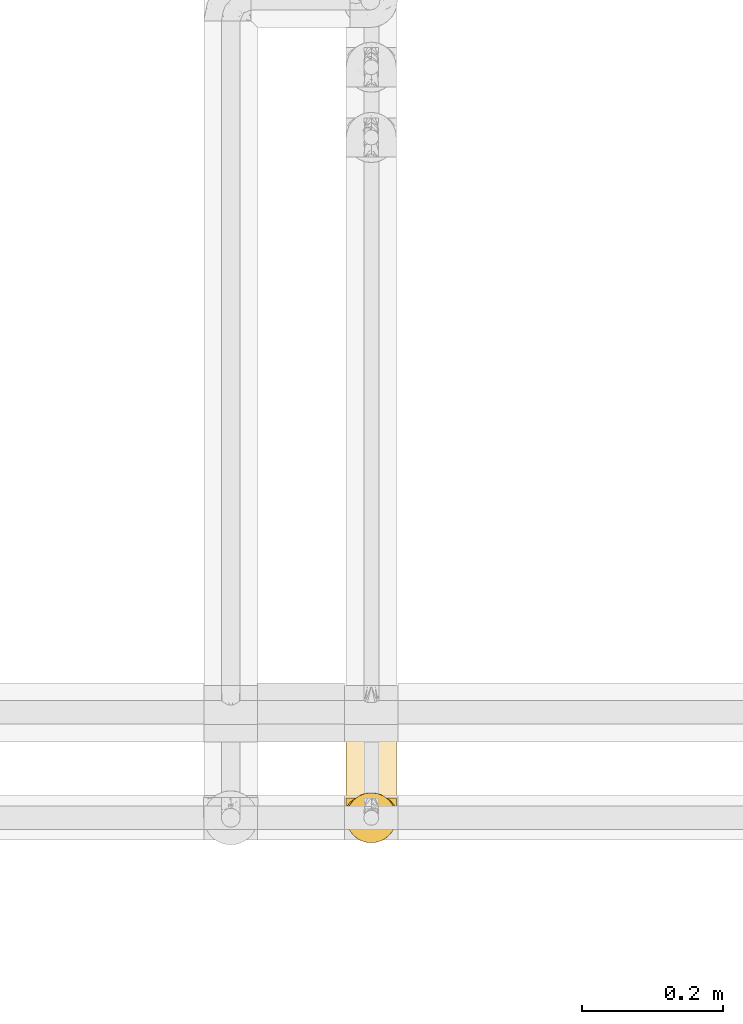
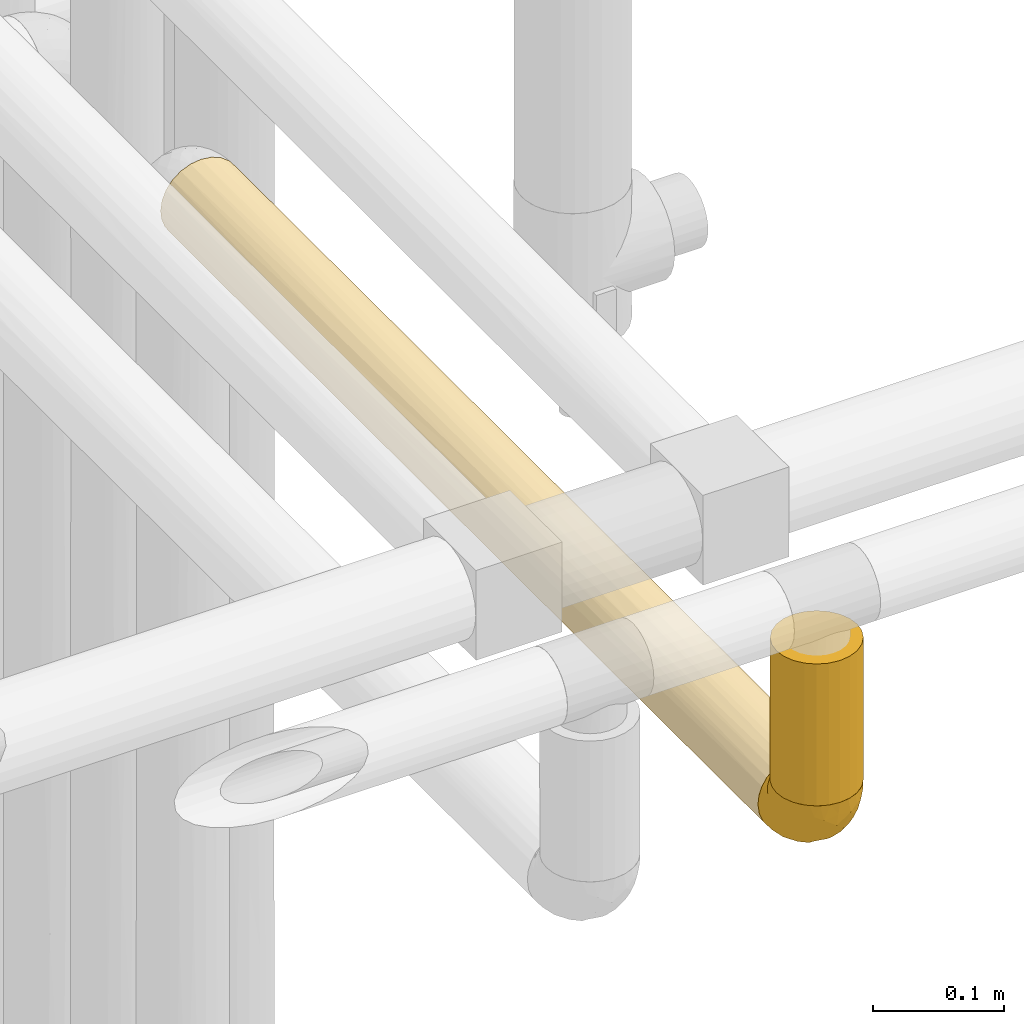
# One storey, part 55 of 827: 3 coverings.
"""IFC2X3 building model written with IfcOpenShell, lengths in millimetres."""

from ifc_helpers import new_model, entity, si_unit, converted_unit, derived_unit, direction, frame, origin, place, context, subcontext, project, spatial, faceted_brep, element, save


model = new_model("IFC2X3")

# Units and contexts
model_context = context("Model", 3, precision=0.01, world=origin(), true_north=direction((6.12303176911189e-17, 1.0)))
body_context = subcontext(model_context, "Body", "Model", "MODEL_VIEW")
ifc_project = project(units=[si_unit("LENGTHUNIT", "METRE", prefix="MILLI"), si_unit("AREAUNIT", "SQUARE_METRE"), si_unit("VOLUMEUNIT", "CUBIC_METRE"), converted_unit("PLANEANGLEUNIT", "DEGREE", entity("IfcRatioMeasure", 0.0174532925199433), si_unit("PLANEANGLEUNIT", "RADIAN"), dimensions=[0, 0, 0, 0, 0, 0, 0]), si_unit("MASSUNIT", "GRAM", prefix="KILO"), derived_unit("MASSDENSITYUNIT", [(si_unit("MASSUNIT", "GRAM", prefix="KILO"), 1), (si_unit("LENGTHUNIT", "METRE"), -3)]), derived_unit("MOMENTOFINERTIAUNIT", [(si_unit("LENGTHUNIT", "METRE"), 4)]), si_unit("TIMEUNIT", "SECOND"), si_unit("FREQUENCYUNIT", "HERTZ"), si_unit("THERMODYNAMICTEMPERATUREUNIT", "DEGREE_CELSIUS"), derived_unit("THERMALTRANSMITTANCEUNIT", [(si_unit("MASSUNIT", "GRAM", prefix="KILO"), 1), (si_unit("THERMODYNAMICTEMPERATUREUNIT", "KELVIN"), -1), (si_unit("TIMEUNIT", "SECOND"), -3)]), derived_unit("VOLUMETRICFLOWRATEUNIT", [(si_unit("LENGTHUNIT", "METRE"), 3), (si_unit("TIMEUNIT", "SECOND"), -1)]), derived_unit("MASSFLOWRATEUNIT", [(si_unit("MASSUNIT", "GRAM", prefix="KILO"), 1), (si_unit("TIMEUNIT", "SECOND"), -1)]), derived_unit("ROTATIONALFREQUENCYUNIT", [(si_unit("TIMEUNIT", "SECOND"), -1)]), si_unit("ELECTRICCURRENTUNIT", "AMPERE"), si_unit("ELECTRICVOLTAGEUNIT", "VOLT"), si_unit("POWERUNIT", "WATT"), si_unit("FORCEUNIT", "NEWTON", prefix="KILO"), si_unit("ILLUMINANCEUNIT", "LUX"), si_unit("LUMINOUSFLUXUNIT", "LUMEN"), si_unit("LUMINOUSINTENSITYUNIT", "CANDELA"), derived_unit("USERDEFINED", [(si_unit("MASSUNIT", "GRAM", prefix="KILO"), -1), (si_unit("LENGTHUNIT", "METRE"), -2), (si_unit("TIMEUNIT", "SECOND"), 3), (si_unit("LUMINOUSFLUXUNIT", "LUMEN"), 1)]), derived_unit("LINEARVELOCITYUNIT", [(si_unit("LENGTHUNIT", "METRE"), 1), (si_unit("TIMEUNIT", "SECOND"), -1)]), si_unit("PRESSUREUNIT", "PASCAL"), derived_unit("USERDEFINED", [(si_unit("LENGTHUNIT", "METRE"), -2), (si_unit("MASSUNIT", "GRAM", prefix="KILO"), 1), (si_unit("TIMEUNIT", "SECOND"), -2)]), derived_unit("LINEARFORCEUNIT", [(si_unit("MASSUNIT", "GRAM", prefix="KILO"), 1), (si_unit("LENGTHUNIT", "METRE"), 1), (si_unit("TIMEUNIT", "SECOND"), -2), (si_unit("LENGTHUNIT", "METRE"), -1)]), derived_unit("PLANARFORCEUNIT", [(si_unit("MASSUNIT", "GRAM", prefix="KILO"), 1), (si_unit("LENGTHUNIT", "METRE"), 1), (si_unit("TIMEUNIT", "SECOND"), -2), (si_unit("LENGTHUNIT", "METRE"), -2)])], contexts=[model_context])

# Site, building, storey
site_placement = place(None, origin())
site = spatial("IfcSite", under=ifc_project, at=site_placement, CompositionType="ELEMENT")
building_placement = place(site_placement, origin())
building = spatial("IfcBuilding", under=site, at=building_placement, CompositionType="ELEMENT")
storey_placement = place(building_placement, frame((0.0, 0.0, 28200.0)))
storey = spatial("IfcBuildingStorey", under=building, at=storey_placement, Name="08", CompositionType="ELEMENT", Elevation=28200.0)

# Coverings
covering_1_placement = place(storey_placement, frame((17891.28, 9619.2, 2614.48)))
element("IfcCovering", 1, at=covering_1_placement, inside=storey, Name=":ADSK_", ObjectType=":ADSK_", PredefinedType="INSULATION", context=body_context, shape_type="Brep", body=[
    faceted_brep([(12.04, 914.0, 62.45), (19.42, 914.0, 68.12), (28.02, 914.0, 71.68), (37.25, 914.0, 72.9), (46.47, 914.0, 71.68), (55.07, 914.0, 68.12), (62.45, 914.0, 62.45), (68.12, 914.0, 55.07), (71.68, 914.0, 46.47), (72.9, 914.0, 37.25), (71.99, 914.0, 29.26), (69.32, 914.0, 21.68), (65.02, 914.0, 14.89), (59.31, 914.0, 9.25), (15.18, 914.0, 9.25), (9.47, 914.0, 14.89), (5.17, 914.0, 21.68), (2.5, 914.0, 29.26), (1.6, 914.0, 37.25), (2.81, 914.0, 46.47), (6.37, 914.0, 55.07), (59.31, 1.6, 65.25), (15.18, 1.6, 65.25), (9.47, 1.6, 59.6), (5.17, 1.6, 52.81), (2.5, 1.6, 45.24), (1.6, 1.6, 37.25), (2.81, 1.6, 28.02), (6.37, 1.6, 19.42), (12.04, 1.6, 12.04), (19.42, 1.6, 6.37), (28.02, 1.6, 2.81), (37.25, 1.6, 1.6), (46.47, 1.6, 2.81), (55.07, 1.6, 6.37), (62.45, 1.6, 12.04), (68.12, 1.6, 19.42), (71.68, 1.6, 28.02), (72.9, 1.6, 37.25), (71.99, 1.6, 45.24), (69.32, 1.6, 52.81), (65.02, 1.6, 59.6), (71.42, 331.97, 27.11), (72.9, 249.32, 37.25), (37.25, 245.49, 1.6), (43.48, 174.27, 2.14), (65.53, 242.64, 15.54), (57.15, 458.31, 7.67), (62.55, 579.77, 12.13), (72.9, 705.52, 37.25), (70.87, 659.33, 25.39), (57.02, 693.42, 7.58), (48.92, 908.32, 3.56), (54.35, 910.72, 5.97), (67.36, 502.79, 18.17), (68.86, 325.58, 20.78), (50.2, 461.14, 4.03), (67.36, 724.75, 18.17), (58.95, 214.6, 8.96), (50.89, 256.26, 4.31), (37.25, 489.39, 1.6), (44.09, 367.44, 2.26), (72.9, 497.04, 37.25), (37.25, 697.87, 1.6), (43.17, 906.85, 2.09), (46.16, 626.74, 2.73), (72.9, 210.08, 37.25), (37.25, 906.35, 1.6), (72.9, 418.56, 37.25), (72.9, 666.28, 37.25), (16.83, 235.14, 8.02), (11.24, 302.68, 12.86), (17.34, 458.31, 7.67), (28.33, 626.74, 2.73), (30.4, 367.44, 2.26), (24.29, 461.14, 4.03), (2.25, 373.18, 30.45), (1.6, 249.32, 37.25), (1.6, 418.56, 37.25), (1.6, 497.04, 37.25), (3.0, 601.28, 27.35), (7.13, 502.79, 18.17), (4.31, 265.31, 23.6), (25.57, 908.32, 3.56), (31.32, 906.85, 2.09), (23.6, 256.26, 4.31), (7.45, 198.07, 17.66), (20.14, 910.72, 5.97), (17.47, 693.42, 7.58), (11.94, 579.77, 12.13), (1.6, 666.28, 37.25), (1.6, 705.52, 37.25), (2.16, 177.62, 30.94), (1.6, 210.08, 37.25), (7.13, 724.75, 18.17), (31.01, 174.27, 2.14), (7.13, 190.84, 56.32), (3.62, 256.26, 49.1), (28.33, 288.86, 71.76), (30.4, 548.16, 72.23), (24.29, 454.46, 70.46), (5.17, 714.59, 52.8), (3.07, 583.63, 47.38), (11.94, 335.82, 62.36), (31.32, 8.75, 72.4), (37.25, 217.73, 72.9), (17.34, 457.29, 66.82), (15.54, 700.99, 65.53), (8.96, 672.96, 58.95), (7.13, 412.8, 56.32), (17.47, 222.17, 66.91), (20.14, 4.87, 68.52), (25.57, 7.28, 70.93), (23.6, 659.34, 70.18), (37.25, 426.21, 72.9), (37.25, 670.1, 72.9), (31.01, 741.33, 72.35), (37.25, 9.25, 72.9), (48.92, 7.28, 70.93), (57.02, 222.17, 66.91), (46.16, 288.86, 71.76), (43.17, 8.75, 72.4), (58.95, 700.99, 65.53), (50.89, 659.34, 70.18), (54.35, 4.87, 68.52), (50.2, 454.46, 70.46), (44.09, 548.16, 72.23), (57.15, 457.29, 66.82), (62.55, 335.82, 62.36), (67.36, 190.84, 56.32), (43.48, 741.33, 72.35), (71.42, 583.63, 47.38), (70.87, 256.26, 49.1), (67.36, 412.8, 56.32), (68.86, 590.01, 53.71), (65.53, 672.96, 58.95)], [[[0, 1, 2, 3, 4, 5, 6, 7, 8, 9, 10, 11, 12, 13, 14, 15, 16, 17, 18, 19, 20]], [[21, 22, 23, 24, 25, 26, 27, 28, 29, 30, 31, 32, 33, 34, 35, 36, 37, 38, 39, 40, 41]], [[42, 43, 37]], [[44, 45, 32]], [[46, 47, 48]], [[10, 49, 50]], [[51, 52, 53]], [[47, 51, 48]], [[54, 50, 42]], [[36, 46, 55]], [[51, 47, 56]], [[50, 54, 57]], [[11, 10, 50]], [[48, 13, 12]], [[57, 12, 11]], [[47, 58, 59]], [[48, 12, 57]], [[60, 61, 44]], [[50, 62, 42]], [[63, 64, 65]], [[37, 43, 66, 38]], [[64, 52, 65]], [[34, 33, 59]], [[53, 13, 51]], [[51, 65, 52]], [[67, 64, 63]], [[65, 56, 61]], [[35, 46, 36]], [[37, 36, 55]], [[58, 35, 34]], [[56, 59, 61]], [[42, 62, 68, 43]], [[46, 35, 58]], [[55, 46, 54]], [[48, 51, 13]], [[46, 48, 54]], [[44, 61, 45]], [[50, 57, 11]], [[48, 57, 54]], [[65, 61, 60]], [[45, 59, 33]], [[59, 58, 34]], [[46, 58, 47]], [[51, 56, 65]], [[47, 59, 56]], [[59, 45, 61]], [[32, 45, 33]], [[65, 60, 63]], [[49, 10, 9]], [[50, 49, 69, 62]], [[54, 42, 55]], [[55, 42, 37]], [[70, 71, 72]], [[73, 74, 75]], [[74, 60, 44]], [[76, 77, 78, 79]], [[80, 81, 82]], [[73, 83, 84]], [[85, 31, 30]], [[81, 86, 82]], [[70, 29, 71]], [[14, 87, 88]], [[83, 73, 88]], [[84, 63, 73]], [[76, 80, 82]], [[14, 89, 15]], [[86, 28, 82]], [[80, 79, 90, 91]], [[92, 26, 93, 77]], [[88, 72, 89]], [[16, 94, 80]], [[81, 89, 71]], [[28, 27, 82]], [[94, 16, 15]], [[75, 88, 73]], [[17, 91, 18]], [[17, 16, 80]], [[95, 85, 74]], [[88, 87, 83]], [[88, 89, 14]], [[86, 81, 71]], [[17, 80, 91]], [[89, 94, 15]], [[71, 89, 72]], [[89, 81, 94]], [[72, 85, 70]], [[29, 28, 86]], [[77, 76, 92]], [[74, 73, 60]], [[31, 95, 32]], [[80, 94, 81]], [[95, 74, 44]], [[74, 85, 75]], [[80, 76, 79]], [[92, 82, 27]], [[85, 72, 75]], [[88, 75, 72]], [[82, 92, 76]], [[26, 92, 27]], [[32, 95, 44]], [[85, 95, 31]], [[85, 30, 70]], [[29, 70, 30]], [[63, 84, 67]], [[63, 60, 73]], [[29, 86, 71]], [[96, 97, 24]], [[98, 99, 100]], [[24, 23, 96]], [[19, 101, 20]], [[78, 97, 102]], [[23, 22, 103]], [[104, 105, 98]], [[25, 97, 93]], [[19, 102, 101]], [[106, 107, 108]], [[109, 102, 97]], [[19, 90, 102]], [[103, 22, 110]], [[103, 96, 23]], [[22, 111, 110]], [[0, 107, 1]], [[25, 24, 97]], [[110, 112, 98]], [[98, 112, 104]], [[97, 78, 77, 93]], [[100, 110, 98]], [[1, 107, 113]], [[110, 106, 103]], [[99, 114, 115]], [[113, 2, 1]], [[110, 111, 112]], [[101, 109, 108]], [[108, 0, 20]], [[93, 26, 25]], [[116, 113, 99]], [[101, 108, 20]], [[108, 109, 103]], [[108, 103, 106]], [[103, 109, 96]], [[99, 98, 114]], [[2, 116, 3]], [[97, 96, 109]], [[116, 99, 115]], [[99, 113, 100]], [[108, 107, 0]], [[113, 107, 106]], [[113, 106, 100]], [[110, 100, 106]], [[3, 116, 115]], [[113, 116, 2]], [[105, 104, 117]], [[105, 114, 98]], [[19, 18, 91, 90]], [[102, 90, 79, 78]], [[109, 101, 102]], [[118, 119, 120]], [[121, 118, 120]], [[122, 6, 5]], [[5, 4, 123]], [[117, 121, 105]], [[119, 124, 21]], [[121, 120, 105]], [[125, 123, 126]], [[127, 119, 128]], [[128, 41, 129]], [[3, 115, 130]], [[131, 69, 8]], [[125, 126, 120]], [[114, 126, 115]], [[40, 39, 132]], [[132, 68, 131]], [[129, 132, 133]], [[131, 68, 62, 69]], [[8, 7, 134]], [[134, 7, 135]], [[119, 118, 124]], [[39, 66, 132]], [[128, 21, 41]], [[135, 127, 128]], [[131, 133, 132]], [[127, 122, 123]], [[119, 127, 125]], [[129, 41, 40]], [[8, 69, 49, 9]], [[6, 135, 7]], [[135, 6, 122]], [[134, 135, 133]], [[128, 119, 21]], [[135, 128, 133]], [[115, 126, 130]], [[132, 129, 40]], [[128, 129, 133]], [[120, 126, 114]], [[130, 123, 4]], [[123, 122, 5]], [[135, 122, 127]], [[119, 125, 120]], [[127, 123, 125]], [[123, 130, 126]], [[3, 130, 4]], [[120, 114, 105]], [[66, 39, 38]], [[132, 66, 43, 68]], [[133, 131, 134]], [[134, 131, 8]], [[53, 52, 64, 67, 84, 83, 87, 14, 13]], [[124, 118, 121, 117, 104, 112, 111, 22, 21]]]),
])
covering_2_placement = place(storey_placement, frame((17891.28, 9555.55, 2678.13)))
element("IfcCovering", 2, at=covering_2_placement, inside=storey, Name=":ADSK_", ObjectType=":ADSK_", PredefinedType="INSULATION", context=body_context, shape_type="Brep", body=[
    faceted_brep([(62.45, 12.04, 133.87), (68.12, 19.42, 133.87), (71.68, 28.02, 133.87), (72.9, 37.25, 133.87), (71.68, 46.47, 133.87), (68.12, 55.07, 133.87), (62.45, 62.45, 133.87), (55.07, 68.12, 133.87), (46.47, 71.68, 133.87), (37.25, 72.9, 133.87), (28.02, 71.68, 133.87), (19.42, 68.12, 133.87), (12.04, 62.45, 133.87), (6.37, 55.07, 133.87), (2.81, 46.47, 133.87), (1.6, 37.25, 133.87), (2.81, 28.02, 133.87), (6.37, 19.42, 133.87), (12.04, 12.04, 133.87), (19.42, 6.37, 133.87), (28.02, 2.81, 133.87), (37.25, 1.6, 133.87), (46.47, 2.81, 133.87), (55.07, 6.37, 133.87), (71.68, 28.02, 1.6), (68.12, 19.42, 1.6), (62.45, 12.04, 1.6), (55.07, 6.37, 1.6), (46.47, 2.81, 1.6), (37.25, 1.6, 1.6), (28.02, 2.81, 1.6), (19.42, 6.37, 1.6), (12.04, 12.04, 1.6), (6.37, 19.42, 1.6), (2.81, 28.02, 1.6), (1.6, 37.25, 1.6), (2.5, 45.24, 1.6), (5.17, 52.81, 1.6), (9.47, 59.6, 1.6), (15.18, 65.25, 1.6), (59.31, 65.25, 1.6), (65.02, 59.6, 1.6), (69.32, 52.81, 1.6), (71.99, 45.24, 1.6), (72.9, 37.25, 1.6), (54.35, 68.52, 4.87), (48.92, 70.93, 7.28), (43.17, 72.4, 8.75), (37.25, 72.9, 9.25), (31.32, 72.4, 8.75), (25.57, 70.93, 7.28), (20.14, 68.52, 4.87)], [[[0, 1, 2, 3, 4, 5, 6, 7, 8, 9, 10, 11, 12, 13, 14, 15, 16, 17, 18, 19, 20, 21, 22, 23]], [[24, 25, 26, 27, 28, 29, 30, 31, 32, 33, 34, 35, 36, 37, 38, 39, 40, 41, 42, 43, 44]], [[34, 33, 17, 16]], [[35, 34, 16, 15]], [[33, 32, 18, 17]], [[20, 19, 31, 30]], [[21, 20, 30, 29]], [[32, 31, 19, 18]], [[22, 21, 29, 28]], [[23, 22, 28, 27]], [[27, 26, 0, 23]], [[2, 1, 25, 24]], [[3, 2, 24, 44]], [[26, 25, 1, 0]], [[3, 44, 43]], [[4, 43, 42]], [[5, 42, 41]], [[3, 43, 4]], [[4, 42, 5]], [[41, 6, 5]], [[41, 40, 6]], [[40, 45, 7]], [[46, 47, 8]], [[45, 46, 7]], [[7, 46, 8]], [[9, 8, 47]], [[48, 9, 47]], [[40, 7, 6]], [[49, 50, 10]], [[51, 39, 11]], [[50, 51, 11]], [[48, 49, 9]], [[9, 49, 10]], [[50, 11, 10]], [[39, 12, 11]], [[13, 38, 37]], [[14, 37, 36]], [[15, 36, 35]], [[12, 38, 13]], [[13, 37, 14]], [[36, 15, 14]], [[38, 12, 39]], [[51, 50, 49, 48, 47, 46, 45, 40, 39]]]),
])
covering_3_placement = place(storey_placement, frame((17891.28, 9555.55, 2614.48)))
element("IfcCovering", 3, at=covering_3_placement, inside=storey, Name=":ADSK_", ObjectType=":ADSK_", PredefinedType="INSULATION", context=body_context, shape_type="Brep", body=[
    faceted_brep([(5.13, 21.77, 65.25), (9.38, 15.01, 65.25), (15.02, 9.37, 65.25), (21.78, 5.12, 65.25), (29.32, 2.49, 65.25), (37.25, 1.6, 65.25), (45.18, 2.49, 65.25), (52.72, 5.13, 65.25), (59.48, 9.38, 65.25), (65.12, 15.02, 65.25), (69.37, 21.78, 65.25), (72.0, 29.32, 65.25), (72.9, 37.25, 65.25), (72.01, 45.15, 65.25), (69.39, 52.65, 65.25), (65.18, 59.39, 65.25), (59.59, 65.02, 65.25), (57.53, 65.02, 65.25), (56.06, 65.02, 65.25), (54.3, 65.02, 65.25), (52.53, 65.02, 65.25), (50.77, 65.02, 65.25), (49.0, 65.02, 65.25), (47.24, 65.02, 65.25), (45.47, 65.02, 65.25), (43.71, 65.02, 65.25), (41.94, 65.02, 65.25), (40.18, 65.02, 65.25), (38.41, 65.02, 65.25), (36.65, 65.02, 65.25), (34.88, 65.02, 65.25), (33.12, 65.02, 65.25), (31.35, 65.02, 65.25), (29.3, 65.02, 65.25), (27.24, 65.02, 65.25), (25.18, 65.02, 65.25), (23.13, 65.02, 65.25), (21.07, 65.02, 65.25), (19.01, 65.02, 65.25), (16.96, 65.02, 65.25), (14.9, 65.02, 65.25), (9.3, 59.38, 65.25), (5.09, 52.64, 65.25), (2.48, 45.13, 65.25), (1.6, 37.25, 65.25), (2.49, 29.31, 65.25), (59.59, 65.25, 65.02), (65.19, 65.25, 59.38), (69.4, 65.25, 52.65), (72.01, 65.25, 45.14), (72.9, 65.25, 37.25), (71.68, 65.25, 28.02), (68.12, 65.25, 19.42), (62.45, 65.25, 12.04), (55.07, 65.25, 6.37), (46.47, 65.25, 2.81), (37.25, 65.25, 1.6), (28.02, 65.25, 2.81), (19.42, 65.25, 6.37), (12.04, 65.25, 12.04), (6.37, 65.25, 19.42), (2.81, 65.25, 28.02), (1.6, 65.25, 37.25), (2.48, 65.25, 45.14), (5.09, 65.25, 52.65), (9.3, 65.25, 59.38), (14.9, 65.25, 65.02), (15.93, 65.25, 65.02), (17.69, 65.25, 65.02), (19.09, 65.25, 65.02), (20.49, 65.25, 65.02), (21.88, 65.25, 65.02), (23.28, 65.25, 65.02), (24.68, 65.25, 65.02), (26.07, 65.25, 65.02), (27.47, 65.25, 65.02), (28.87, 65.25, 65.02), (30.26, 65.25, 65.02), (31.66, 65.25, 65.02), (33.06, 65.25, 65.02), (34.45, 65.25, 65.02), (35.85, 65.25, 65.02), (37.25, 65.25, 65.02), (39.01, 65.25, 65.02), (40.77, 65.25, 65.02), (42.54, 65.25, 65.02), (44.3, 65.25, 65.02), (46.07, 65.25, 65.02), (47.83, 65.25, 65.02), (49.6, 65.25, 65.02), (51.36, 65.25, 65.02), (53.42, 65.25, 65.02), (55.48, 65.25, 65.02), (57.53, 65.25, 65.02), (24.13, 65.08, 65.09), (22.58, 65.09, 65.08), (46.76, 65.09, 65.08), (45.43, 65.1, 65.08), (51.49, 65.08, 65.1), (35.2, 65.09, 65.08), (58.19, 65.09, 65.09), (56.8, 65.09, 65.09), (32.4, 65.09, 65.09), (30.96, 65.1, 65.08), (16.26, 65.08, 65.1), (14.9, 65.09, 65.09), (28.17, 65.08, 65.1), (26.81, 65.09, 65.08), (55.49, 65.08, 65.09), (44.1, 65.09, 65.09), (42.83, 65.07, 65.1), (36.55, 65.1, 65.08), (37.92, 65.09, 65.08), (29.48, 65.1, 65.08), (39.3, 65.07, 65.11), (48.12, 65.07, 65.1), (49.39, 65.09, 65.09), (17.58, 65.08, 65.1), (33.81, 65.09, 65.09), (41.72, 65.13, 65.06), (54.15, 65.1, 65.08), (52.82, 65.09, 65.08), (40.57, 65.09, 65.09), (21.1, 65.1, 65.08), (19.79, 65.09, 65.09), (59.59, 65.09, 65.09), (25.46, 65.09, 65.08), (70.91, 53.74, 53.73), (68.25, 57.19, 58.66), (72.9, 51.25, 41.0), (72.9, 59.77, 38.71), (72.9, 41.0, 51.25), (64.57, 61.64, 61.64), (72.9, 46.12, 46.12), (72.9, 38.71, 59.77), (46.9, 13.0, 31.28), (49.02, 5.55, 49.86), (37.25, 6.44, 40.89), (72.16, 55.39, 31.44), (72.12, 48.48, 34.1), (65.96, 39.63, 23.33), (58.95, 43.5, 13.33), (65.53, 52.38, 17.24), (70.18, 49.31, 26.77), (70.18, 58.01, 24.24), (67.43, 22.23, 46.39), (67.43, 19.14, 56.32), (62.46, 13.73, 51.97), (72.19, 39.1, 41.92), (53.36, 15.38, 32.23), (43.86, 46.7, 5.01), (50.89, 49.4, 6.41), (37.25, 4.12, 52.55), (58.95, 55.35, 9.84), (55.84, 23.83, 24.05), (59.19, 19.0, 33.5), (71.35, 32.44, 45.31), (70.9, 26.73, 55.32), (56.22, 8.12, 54.18), (67.42, 31.34, 32.73), (70.63, 38.81, 34.55), (61.45, 16.11, 42.44), (56.22, 11.96, 41.89), (48.22, 20.31, 22.65), (51.43, 38.81, 10.6), (45.24, 35.48, 10.01), (50.08, 28.94, 15.9), (43.45, 25.21, 16.46), (37.25, 20.24, 20.24), (37.25, 13.34, 30.56), (37.25, 52.55, 4.12), (59.41, 33.16, 19.45), (62.46, 27.33, 27.92), (64.67, 22.86, 37.29), (68.35, 27.48, 40.02), (37.25, 40.89, 6.44), (37.25, 30.56, 13.34), (4.31, 54.41, 25.04), (30.45, 46.71, 5.04), (25.32, 26.31, 17.52), (27.59, 12.98, 31.3), (12.04, 13.72, 51.97), (18.28, 8.12, 54.19), (8.96, 46.04, 19.41), (15.54, 51.06, 10.78), (16.32, 35.69, 16.67), (7.06, 22.22, 46.4), (7.06, 19.13, 56.32), (3.6, 26.72, 55.32), (19.36, 19.65, 28.05), (2.28, 51.87, 32.97), (1.6, 51.25, 41.0), (1.6, 58.25, 39.12), (1.6, 38.71, 59.77), (25.07, 54.36, 4.71), (8.96, 56.5, 16.32), (29.08, 34.9, 10.37), (23.6, 43.16, 8.45), (25.48, 5.54, 49.86), (7.69, 35.66, 27.54), (4.1, 47.21, 28.28), (18.28, 11.95, 41.9), (2.18, 46.27, 36.5), (2.39, 39.95, 40.35), (1.6, 41.0, 51.25), (1.6, 46.12, 46.12), (12.04, 18.27, 40.24), (3.15, 32.43, 45.3), (2.24, 58.69, 31.14), (12.04, 27.31, 27.93), (6.5, 29.52, 36.19), (11.64, 35.02, 21.94), (3.92, 40.81, 32.75), (3.58, 53.74, 53.73), (6.24, 58.66, 57.19), (9.92, 61.64, 61.64)], [[[0, 1, 2, 3, 4, 5, 6, 7, 8, 9, 10, 11, 12, 13, 14, 15, 16, 17, 18, 19, 20, 21, 22, 23, 24, 25, 26, 27, 28, 29, 30, 31, 32, 33, 34, 35, 36, 37, 38, 39, 40, 41, 42, 43, 44, 45]], [[46, 47, 48, 49, 50, 51, 52, 53, 54, 55, 56, 57, 58, 59, 60, 61, 62, 63, 64, 65, 66, 67, 68, 69, 70, 71, 72, 73, 74, 75, 76, 77, 78, 79, 80, 81, 82, 83, 84, 85, 86, 87, 88, 89, 90, 91, 92, 93]], [[94, 72, 95]], [[96, 87, 97]], [[20, 98, 21]], [[99, 81, 80]], [[100, 93, 101]], [[102, 103, 32]], [[104, 105, 40]], [[67, 105, 104]], [[106, 107, 34]], [[18, 101, 108]], [[109, 85, 110]], [[36, 94, 95]], [[81, 111, 82]], [[29, 28, 112]], [[17, 101, 18]], [[103, 113, 33]], [[24, 96, 97]], [[28, 114, 112]], [[115, 22, 116]], [[31, 102, 32]], [[68, 104, 117]], [[31, 118, 102]], [[84, 119, 85]], [[120, 91, 121]], [[23, 22, 115]], [[114, 27, 122]], [[123, 37, 95]], [[117, 124, 69]], [[67, 66, 105]], [[104, 39, 117]], [[123, 124, 37]], [[100, 17, 16]], [[100, 125, 46]], [[17, 100, 101]], [[107, 126, 35]], [[92, 108, 101]], [[115, 88, 96]], [[114, 122, 83]], [[101, 93, 92]], [[93, 100, 46]], [[16, 125, 100]], [[108, 19, 18]], [[120, 121, 19]], [[108, 92, 120]], [[19, 108, 120]], [[67, 104, 68]], [[39, 104, 40]], [[69, 68, 117]], [[117, 39, 38]], [[70, 124, 123]], [[124, 70, 69]], [[38, 124, 117]], [[124, 38, 37]], [[72, 71, 95]], [[71, 123, 95]], [[71, 70, 123]], [[126, 94, 35]], [[37, 36, 95]], [[75, 74, 107]], [[73, 72, 94]], [[94, 36, 35]], [[94, 126, 73]], [[74, 73, 126]], [[106, 76, 75]], [[76, 106, 113]], [[113, 106, 33]], [[107, 35, 34]], [[106, 34, 33]], [[126, 107, 74]], [[107, 106, 75]], [[78, 77, 103]], [[77, 113, 103]], [[77, 76, 113]], [[102, 78, 103]], [[33, 32, 103]], [[80, 79, 118]], [[102, 118, 79]], [[112, 111, 29]], [[118, 31, 30]], [[79, 78, 102]], [[99, 111, 81]], [[112, 82, 111]], [[111, 99, 29]], [[30, 29, 99]], [[112, 83, 82]], [[27, 114, 28]], [[99, 118, 30]], [[118, 99, 80]], [[114, 83, 112]], [[84, 83, 122]], [[109, 110, 25]], [[122, 27, 26]], [[119, 110, 85]], [[20, 19, 121]], [[25, 110, 26]], [[91, 120, 92]], [[90, 98, 121]], [[121, 91, 90]], [[23, 115, 96]], [[88, 115, 116]], [[116, 98, 89]], [[89, 88, 116]], [[23, 96, 24]], [[87, 96, 88]], [[25, 24, 109]], [[97, 87, 86]], [[90, 89, 98]], [[116, 22, 21]], [[122, 26, 119]], [[86, 85, 109]], [[109, 97, 86]], [[97, 109, 24]], [[110, 119, 26]], [[122, 119, 84]], [[121, 98, 20]], [[21, 98, 116]], [[48, 127, 49]], [[48, 47, 128]], [[49, 129, 130, 50]], [[129, 49, 127]], [[131, 127, 13]], [[46, 125, 132]], [[16, 15, 132]], [[127, 128, 14]], [[127, 131, 133, 129]], [[14, 13, 127]], [[13, 12, 134, 131]], [[46, 132, 47]], [[48, 128, 127]], [[47, 132, 128]], [[15, 128, 132]], [[125, 16, 132]], [[15, 14, 128]], [[135, 136, 137]], [[138, 129, 139]], [[140, 141, 142]], [[143, 144, 138]], [[145, 146, 147]], [[133, 148, 139]], [[134, 12, 11]], [[136, 135, 149]], [[150, 55, 151]], [[136, 6, 152]], [[153, 54, 53]], [[52, 144, 142]], [[52, 142, 53]], [[54, 153, 151]], [[144, 52, 51]], [[154, 155, 149]], [[156, 131, 157]], [[134, 11, 157]], [[8, 7, 158]], [[147, 9, 8]], [[157, 131, 134]], [[157, 11, 10]], [[146, 157, 10]], [[159, 140, 160]], [[157, 145, 156]], [[161, 162, 155]], [[161, 147, 162]], [[154, 149, 163]], [[150, 164, 165]], [[136, 7, 6]], [[137, 136, 152]], [[162, 158, 136]], [[54, 151, 55]], [[158, 147, 8]], [[166, 167, 165]], [[9, 146, 10]], [[164, 166, 165]], [[168, 135, 137, 169]], [[55, 150, 170]], [[154, 171, 172]], [[139, 148, 160]], [[140, 142, 143]], [[153, 142, 141]], [[51, 50, 130]], [[145, 173, 174]], [[156, 160, 148]], [[6, 5, 152]], [[136, 158, 7]], [[147, 158, 162]], [[147, 146, 9]], [[157, 146, 145]], [[160, 140, 143]], [[140, 172, 171]], [[139, 143, 138]], [[173, 159, 174]], [[170, 150, 175]], [[170, 56, 55]], [[167, 168, 176]], [[176, 175, 165]], [[150, 165, 175]], [[163, 167, 166]], [[176, 165, 167]], [[164, 150, 151]], [[151, 141, 164]], [[171, 164, 141]], [[154, 163, 166]], [[163, 135, 168]], [[166, 164, 171]], [[155, 154, 172]], [[166, 171, 154]], [[140, 171, 141]], [[173, 155, 172]], [[149, 155, 162]], [[159, 173, 172]], [[161, 145, 147]], [[140, 159, 172]], [[174, 160, 156]], [[136, 149, 162]], [[149, 135, 163]], [[155, 173, 161]], [[145, 161, 173]], [[160, 174, 159]], [[156, 148, 131]], [[156, 145, 174]], [[142, 153, 53]], [[151, 153, 141]], [[138, 51, 130]], [[142, 144, 143]], [[51, 138, 144]], [[129, 138, 130]], [[133, 139, 129]], [[160, 143, 139]], [[168, 167, 163]], [[131, 148, 133]], [[60, 177, 61]], [[175, 178, 170]], [[179, 168, 180]], [[178, 57, 170]], [[181, 182, 2]], [[183, 184, 185]], [[186, 187, 188]], [[189, 185, 179]], [[190, 191, 192]], [[45, 193, 188]], [[194, 184, 58]], [[45, 44, 193]], [[59, 195, 60]], [[60, 195, 177]], [[0, 45, 188]], [[196, 179, 197]], [[180, 137, 198]], [[183, 199, 200]], [[201, 182, 181]], [[1, 181, 2]], [[57, 178, 194]], [[198, 3, 182]], [[198, 152, 4]], [[1, 0, 187]], [[190, 202, 191]], [[203, 204, 205]], [[206, 201, 181]], [[186, 188, 207]], [[188, 204, 207]], [[3, 198, 4]], [[58, 184, 59]], [[187, 181, 1]], [[180, 198, 201]], [[206, 181, 186]], [[180, 189, 179]], [[3, 2, 182]], [[180, 168, 169, 137]], [[204, 188, 193]], [[177, 190, 208]], [[209, 210, 199]], [[210, 186, 207]], [[185, 184, 197]], [[195, 184, 183]], [[205, 202, 203]], [[210, 209, 206]], [[179, 185, 197]], [[211, 209, 199]], [[196, 197, 178]], [[180, 201, 189]], [[152, 198, 137]], [[152, 5, 4]], [[61, 208, 62]], [[198, 182, 201]], [[188, 187, 0]], [[181, 187, 186]], [[203, 210, 207]], [[202, 205, 191]], [[199, 210, 212]], [[57, 56, 170]], [[176, 196, 175]], [[178, 197, 194]], [[179, 176, 168]], [[175, 196, 178]], [[176, 179, 196]], [[184, 194, 197]], [[58, 57, 194]], [[208, 190, 192]], [[200, 190, 177]], [[206, 189, 201]], [[185, 189, 209]], [[62, 208, 192]], [[177, 208, 61]], [[210, 206, 186]], [[189, 206, 209]], [[200, 199, 212]], [[211, 183, 185]], [[184, 195, 59]], [[177, 195, 183]], [[183, 200, 177]], [[202, 200, 212]], [[200, 202, 190]], [[202, 212, 203]], [[210, 203, 212]], [[204, 203, 207]], [[183, 211, 199]], [[185, 209, 211]], [[63, 62, 192, 191]], [[64, 63, 213]], [[64, 213, 214]], [[65, 215, 66]], [[213, 191, 205, 204]], [[43, 204, 193, 44]], [[65, 214, 215]], [[42, 213, 43]], [[215, 105, 66]], [[41, 214, 42]], [[40, 105, 215]], [[65, 64, 214]], [[40, 215, 41]], [[213, 63, 191]], [[42, 214, 213]], [[204, 43, 213]], [[214, 41, 215]]]),
])

save(model, "model.ifc")
